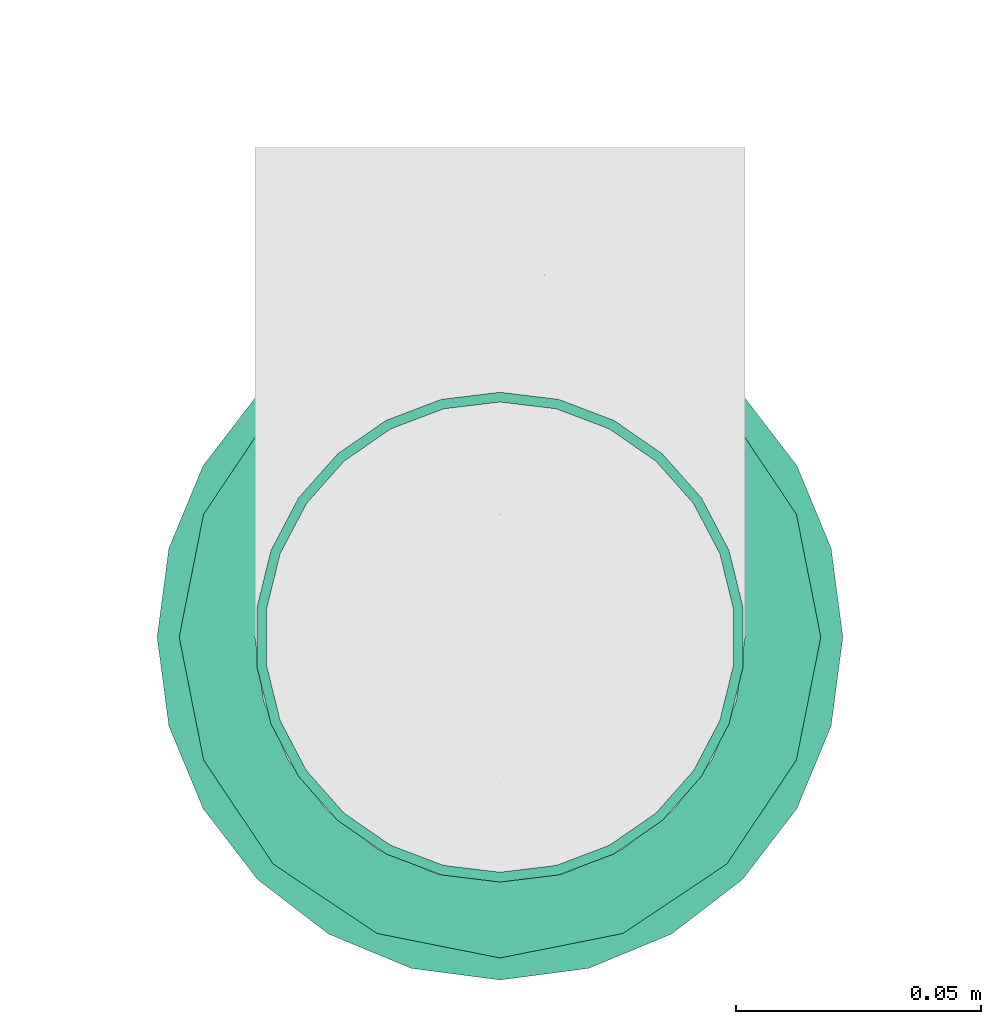
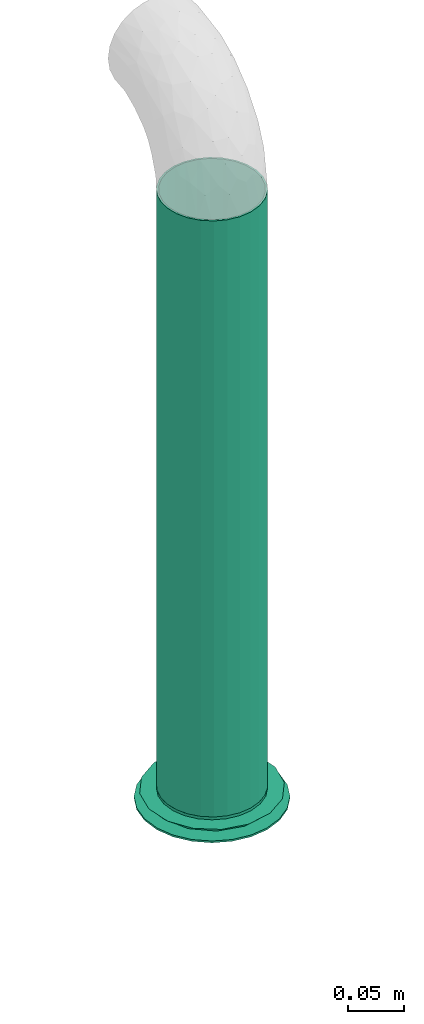
# One storey, part 55 of 103: 1 flow segment, 1 flow terminal.
"""IFC2X3 building model written with IfcOpenShell, lengths in millimetres."""

import ifcopenshell
import ifcopenshell.guid

model = None  # the IFC model being written
_history = None  # IfcOwnerHistory: only IFC2X3 demands one
_inside = {}  # id of a spatial element -> (the spatial element, [elements in it])
_under = {}  # id of a project, library or spatial element -> (it, [spatial elements below it])
_declared = {}  # id of a project -> (the project, [libraries it declares])
_typed = {}  # id of a type object -> (the type object, [elements of that type])
_made_of = {}  # id of a material, layer set ... -> (it, [elements and type objects made of it])


def new_model(schema):
    """Start an empty IFC model of exactly this schema.

    Asked for "IFC4X3", IfcOpenShell would pick the latest addendum, in which some entities
    have other attributes; the version numbers below select the first issue.
    IFC2X3 requires an IfcOwnerHistory on every rooted entity: one is made here for all.
    """
    global model, _history
    if schema == "IFC4X3":
        model = ifcopenshell.file(schema_version=(4, 3, 0, 0))
    else:
        model = ifcopenshell.file(schema=schema)
    _inside.clear()
    _under.clear()
    _declared.clear()
    _typed.clear()
    _made_of.clear()
    _history = None
    if model.schema == "IFC2X3":
        org = make("IfcOrganization", Name="unknown")
        user = make(
            "IfcPersonAndOrganization",
            ThePerson=make("IfcPerson", FamilyName="unknown"),
            TheOrganization=org,
        )
        app = make(
            "IfcApplication",
            ApplicationDeveloper=org,
            Version="unknown",
            ApplicationFullName="unknown",
            ApplicationIdentifier="unknown",
        )
        _history = make(
            "IfcOwnerHistory",
            OwningUser=user,
            OwningApplication=app,
            ChangeAction="ADDED",
            CreationDate=0,
        )
    return model


def make(cls, **values):
    """One entity of the class cls with the attributes given. An attribute that is None is left unset."""
    return model.create_entity(
        cls, **{name: value for name, value in values.items() if value is not None}
    )


def entity(cls, *values):
    """Any entity or typed value of the class cls, its attributes in the order of the schema. None: left unset."""
    e = model.create_entity(cls)
    for i, value in enumerate(values):
        if value is not None:
            e[i] = value
    return e


def rooted(cls, **values):
    """An entity with a GlobalId (a new one), such as an element, a storey or a relation."""
    return make(cls, GlobalId=ifcopenshell.guid.new(), OwnerHistory=_history, **values)


def si_unit(unit_type, name, prefix=None):
    """IfcSIUnit, for example si_unit("LENGTHUNIT", "METRE", prefix="MILLI")."""
    return make("IfcSIUnit", UnitType=unit_type, Prefix=prefix, Name=name)


def converted_unit(unit_type, name, factor, base, dimensions=None, offset=None):
    """IfcConversionBasedUnit, such as the inch: factor (a typed value) times the base unit."""
    return make(
        "IfcConversionBasedUnit"
        if offset is None
        else "IfcConversionBasedUnitWithOffset",
        ConversionOffset=offset,
        Dimensions=None
        if dimensions is None
        else entity("IfcDimensionalExponents", *dimensions),
        UnitType=unit_type,
        Name=name,
        ConversionFactor=make(
            "IfcMeasureWithUnit", ValueComponent=factor, UnitComponent=base
        ),
    )


def derived_unit(unit_type, elements):
    """IfcDerivedUnit: a product of units, each with its exponent."""
    return make(
        "IfcDerivedUnit",
        Elements=[
            make("IfcDerivedUnitElement", Unit=unit, Exponent=power)
            for unit, power in elements
        ],
        UnitType=unit_type,
    )


def assignment(units):
    """IfcUnitAssignment: the units of a project."""
    return None if units is None else make("IfcUnitAssignment", Units=units)


def point(xyz):
    """IfcCartesianPoint."""
    return None if xyz is None else make("IfcCartesianPoint", Coordinates=xyz)


def direction(xyz):
    """IfcDirection."""
    return None if xyz is None else make("IfcDirection", DirectionRatios=xyz)


def frame(location, z_axis=None, x_axis=None):
    """IfcAxis2Placement3D, a coordinate frame: its origin and axes. An axis left out is left unset."""
    return make(
        "IfcAxis2Placement3D",
        Location=point(location),
        Axis=direction(z_axis),
        RefDirection=direction(x_axis),
    )


def frame_2d(location, x_axis=None):
    """IfcAxis2Placement2D, a coordinate frame in the plane: its origin and x axis."""
    return make(
        "IfcAxis2Placement2D", Location=point(location), RefDirection=direction(x_axis)
    )


def origin_with_axes():
    """The frame at (0, 0, 0) with the z axis (0, 0, 1) and the x axis (1, 0, 0) written out."""
    return frame((0.0, 0.0, 0.0), z_axis=(0.0, 0.0, 1.0), x_axis=(1.0, 0.0, 0.0))


def origin_2d_with_axis():
    """The frame at (0, 0) in the plane with the x axis (1, 0) written out."""
    return frame_2d((0.0, 0.0), x_axis=(1.0, 0.0))


def place(relative_to, where):
    """IfcLocalPlacement: puts the frame where relative to a parent placement (None: the world)."""
    return make(
        "IfcLocalPlacement", PlacementRelTo=relative_to, RelativePlacement=where
    )


def context(
    kind, dimensions, precision=None, world=None, true_north=None, identifier=None
):
    """IfcGeometricRepresentationContext, for example the 3D "Model" context."""
    return make(
        "IfcGeometricRepresentationContext",
        ContextIdentifier=identifier,
        ContextType=kind,
        CoordinateSpaceDimension=dimensions,
        Precision=precision,
        WorldCoordinateSystem=world,
        TrueNorth=true_north,
    )


def subcontext(parent, identifier, kind, view, scale=None):
    """IfcGeometricRepresentationSubContext, for example "Body" below "Model"."""
    return make(
        "IfcGeometricRepresentationSubContext",
        ContextIdentifier=identifier,
        ContextType=kind,
        ParentContext=parent,
        TargetScale=scale,
        TargetView=view,
    )


def project(units=None, contexts=None):
    """IfcProject with its units and contexts."""
    return rooted(
        "IfcProject",
        Name="project",
        RepresentationContexts=contexts,
        UnitsInContext=assignment(units),
    )


def spatial(cls, under=None, at=None, **own):
    """A site, building, storey or space (cls), placed at a placement, below another one or the project."""
    s = rooted(cls, ObjectPlacement=at, **own)
    if under is not None:
        _under.setdefault(under.id(), (under, []))[1].append(s)
    return s


def profile(cls, at=None, kind="AREA", **sizes):
    """A parametric profile (cls). Its sizes go by their IFC names, for example OverallWidth=200.0."""
    return make(cls, ProfileType=kind, Position=at, **sizes)


def hollow_circle(**sizes):
    """IfcCircleHollowProfileDef."""
    return profile("IfcCircleHollowProfileDef", **sizes)


def extrude(swept, where, along, depth):
    """IfcExtrudedAreaSolid: the profile swept, set in the frame where, extruded along a direction by depth."""
    return make(
        "IfcExtrudedAreaSolid",
        SweptArea=swept,
        Position=where,
        ExtrudedDirection=direction(along),
        Depth=depth,
    )


def faces_of(points, faces, orient=None, outer=None):
    """IfcFace entities. A face is a list of loops; a loop is a list of indices into points, from 0.

    orient and outer hold one flag for each loop. By default every Orientation is true, the
    first loop of a face is its IfcFaceOuterBound and the others are IfcFaceBound.
    """
    made = []
    for i, loops in enumerate(faces):
        bounds = []
        for j, loop in enumerate(loops):
            is_outer = j == 0 if outer is None else outer[i][j]
            bounds.append(
                make(
                    "IfcFaceOuterBound" if is_outer else "IfcFaceBound",
                    Bound=make("IfcPolyLoop", Polygon=[points[k] for k in loop]),
                    Orientation=True if orient is None else orient[i][j],
                )
            )
        made.append(make("IfcFace", Bounds=bounds))
    return made


def open_shell(faces, orient=None, outer=None):
    """The faces of one IfcOpenShell. surface_model builds it on its shared points."""
    return ("IfcOpenShell", faces, orient, outer)


def surface_model(cls, points, shells):
    """IfcFaceBasedSurfaceModel or IfcShellBasedSurfaceModel (cls): surfaces that need not close."""
    shared = [point(p) for p in points]
    made = [make(c, CfsFaces=faces_of(shared, fs, o, b)) for c, fs, o, b in shells]
    if cls == "IfcFaceBasedSurfaceModel":
        return make(cls, FbsmFaces=made)
    return make(cls, SbsmBoundary=made)


def shape(context_of_items, identifier, shape_type, items):
    """IfcShapeRepresentation: the items that make up one representation, for example the "Body"."""
    return make(
        "IfcShapeRepresentation",
        ContextOfItems=context_of_items,
        RepresentationIdentifier=identifier,
        RepresentationType=shape_type,
        Items=items,
    )


def source(mapping_origin, context_of_items, identifier, shape_type, items):
    """IfcRepresentationMap: a shape defined once, which mapped items show again and again."""
    return make(
        "IfcRepresentationMap",
        MappingOrigin=mapping_origin,
        MappedRepresentation=shape(context_of_items, identifier, shape_type, items),
    )


def transform(
    local_origin,
    x_axis=None,
    y_axis=None,
    z_axis=None,
    scale=None,
    scale2=None,
    scale3=None,
    uniform=True,
):
    """IfcCartesianTransformationOperator3D, or its non-uniform kind. x_axis, y_axis, z_axis: its Axis1, 2, 3."""
    if uniform:
        return make(
            "IfcCartesianTransformationOperator3D",
            Axis1=direction(x_axis),
            Axis2=direction(y_axis),
            LocalOrigin=point(local_origin),
            Scale=scale,
            Axis3=direction(z_axis),
        )
    return make(
        "IfcCartesianTransformationOperator3DnonUniform",
        Axis1=direction(x_axis),
        Axis2=direction(y_axis),
        LocalOrigin=point(local_origin),
        Scale=scale,
        Axis3=direction(z_axis),
        Scale2=scale2,
        Scale3=scale3,
    )


def mapped(mapping_source, mapping_target):
    """IfcMappedItem: shows the shape of a source again, moved by a transform."""
    return make(
        "IfcMappedItem", MappingSource=mapping_source, MappingTarget=mapping_target
    )


def material(Name=None, Category=None):
    """IfcMaterial."""
    return make("IfcMaterial", Name=Name, Category=Category)


def layer(
    of_material, thickness, ventilated=None, Name=None, Category=None, Priority=None
):
    """IfcMaterialLayer: one layer of a wall or slab, of a material (None: an air gap)."""
    return make(
        "IfcMaterialLayer",
        Material=of_material,
        LayerThickness=thickness,
        IsVentilated=ventilated,
        Name=Name,
        Category=Category,
        Priority=Priority,
    )


def layer_set(layers, Name=None):
    """IfcMaterialLayerSet."""
    return make("IfcMaterialLayerSet", MaterialLayers=layers, LayerSetName=Name)


def layer_usage(for_layer_set, set_direction, sense, offset, extent=None):
    """IfcMaterialLayerSetUsage: how a layer set lies in its element."""
    return make(
        "IfcMaterialLayerSetUsage",
        ForLayerSet=for_layer_set,
        LayerSetDirection=set_direction,
        DirectionSense=sense,
        OffsetFromReferenceLine=offset,
        ReferenceExtent=extent,
    )


def made_of(thing, what):
    """Note that an element or type object is made of a material, layer set ...; save() writes the relation."""
    if what is not None:
        _made_of.setdefault(what.id(), (what, []))[1].append(thing)
    return thing


def type_object(cls, material=None, **own):
    """A type object (cls), such as IfcWallType, which elements share."""
    return made_of(rooted(cls, **own), material)


def element(
    cls,
    number,
    at=None,
    inside=None,
    cuts=None,
    type_object=None,
    material=None,
    context=None,
    identifier="Body",
    shape_type=None,
    held_by="IfcProductDefinitionShape",
    body=None,
    shapes=None,
    **own,
):
    """One element of the class cls, such as IfcWall. Its Tag is "e" and its number.

    at: its placement. inside: the storey or other place that contains it. cuts: it is an
    opening in that element (IfcRelVoidsElement). A single representation is given by context,
    identifier, shape_type and body (its items); several are given by shapes. held_by: the class
    of the entity that holds the representations. save() writes the other relations.
    """
    e = rooted(cls, Tag="e%d" % number, ObjectPlacement=at, **own)
    if body is not None:
        shapes = [shape(context, identifier, shape_type, body)]
    if shapes is not None:
        e.Representation = make(held_by, Representations=shapes)
    if inside is not None:
        _inside.setdefault(inside.id(), (inside, []))[1].append(e)
    if cuts is not None:
        rooted(
            "IfcRelVoidsElement", RelatingBuildingElement=cuts, RelatedOpeningElement=e
        )
    if type_object is not None:
        _typed.setdefault(type_object.id(), (type_object, []))[1].append(e)
    return made_of(e, material)


def aggregate(whole, parts):
    """IfcRelAggregates: a whole, such as a stair, and the parts it consists of."""
    return rooted("IfcRelAggregates", RelatingObject=whole, RelatedObjects=parts)


def save(model, path):
    """Write the relations noted so far, then the file.

    IfcRelAggregates (storeys below a building ...), IfcRelContainedInSpatialStructure (elements
    in a storey), IfcRelDefinesByType, IfcRelAssociatesMaterial and IfcRelDeclares: one each for
    every whole, place, type object, material and project.
    """
    for whole, parts in _under.values():
        aggregate(whole, parts)
    for where, things in _inside.values():
        rooted(
            "IfcRelContainedInSpatialStructure",
            RelatedElements=things,
            RelatingStructure=where,
        )
    for kind, things in _typed.values():
        rooted("IfcRelDefinesByType", RelatedObjects=things, RelatingType=kind)
    for what, things in _made_of.values():
        rooted("IfcRelAssociatesMaterial", RelatedObjects=things, RelatingMaterial=what)
    for by, libraries in _declared.values():
        rooted("IfcRelDeclares", RelatingContext=by, RelatedDefinitions=libraries)
    model.write(path)


model = new_model("IFC2X3")

# Units and contexts
model_context = context("Model", 3, precision=1e-05, world=origin_with_axes(), true_north=direction((0.0, 1.0)))
body_context = subcontext(model_context, "Body", "Model", "MODEL_VIEW")
ifc_project = project(units=[si_unit("AREAUNIT", "SQUARE_METRE"), si_unit("VOLUMEUNIT", "CUBIC_METRE", prefix="DECI"), si_unit("TIMEUNIT", "SECOND"), si_unit("THERMODYNAMICTEMPERATUREUNIT", "DEGREE_CELSIUS"), si_unit("PRESSUREUNIT", "PASCAL"), si_unit("MASSUNIT", "GRAM", prefix="KILO"), si_unit("LENGTHUNIT", "METRE", prefix="MILLI"), si_unit("POWERUNIT", "WATT"), si_unit("ELECTRICCURRENTUNIT", "AMPERE"), si_unit("ELECTRICVOLTAGEUNIT", "VOLT"), derived_unit("VOLUMETRICFLOWRATEUNIT", [(si_unit("VOLUMEUNIT", "CUBIC_METRE", prefix="DECI"), 1), (si_unit("TIMEUNIT", "SECOND"), -1)]), derived_unit("LINEARVELOCITYUNIT", [(si_unit("LENGTHUNIT", "METRE"), 1), (si_unit("TIMEUNIT", "SECOND"), -1)]), derived_unit("MASSDENSITYUNIT", [(si_unit("MASSUNIT", "GRAM", prefix="KILO"), 1), (si_unit("VOLUMEUNIT", "CUBIC_METRE"), -1)]), converted_unit("PLANEANGLEUNIT", "DEGREE", entity("IfcRatioMeasure", 0.01745), si_unit("PLANEANGLEUNIT", "RADIAN"), dimensions=[0, 0, 0, 0, 0, 0, 0])], contexts=[model_context])

# Site, building, storey
site_placement = place(None, origin_with_axes())
site = spatial("IfcSite", under=ifc_project, at=site_placement, CompositionType="ELEMENT")
building_placement = place(site_placement, origin_with_axes())
building = spatial("IfcBuilding", under=site, at=building_placement, Name="mc-building", CompositionType="ELEMENT")
storey_placement = place(building_placement, frame((0.0, 0.0, 5900.0), z_axis=(0.0, 0.0, 1.0), x_axis=(1.0, 0.0, 0.0)))
storey = spatial("IfcBuildingStorey", under=building, at=storey_placement, Name="3. Korrus", CompositionType="ELEMENT", Elevation=5900.0)

# Flow terminal
air_terminal_type = type_object("IfcAirTerminalType", Name="100", PredefinedType="NOTDEFINED")
shared_shape_1 = source(origin_with_axes(), body_context, "Body", "SurfaceModel", [
    surface_model("IfcShellBasedSurfaceModel", [(11.2, -70.0, 0.0), (11.2, -67.61481, -18.11733), (11.2, -67.61481, 18.11733), (6.2, -14.64625, -20.15883), (9.2, -22.36867, -22.36867), (6.2, -21.19625, -15.39997), (9.2, 16.375, -28.36233), (6.2, 8.09625, -24.91768), (6.2, 14.64625, -20.15883), (6.2, -8.09625, -24.91768), (9.2, -16.375, -28.36233), (6.2, 21.19625, -15.39997), (9.2, 22.36867, -22.36867), (9.2, -8.1875, -30.55617), (9.2, 8.1875, -30.55617), (9.2, 28.36233, -16.375), (9.2, -28.36233, -16.375), (6.2, 14.64625, 20.15883), (9.2, 22.36867, 22.36867), (6.2, 21.19625, 15.39997), (9.2, -16.375, 28.36233), (6.2, -8.09625, 24.91768), (6.2, -14.64625, 20.15883), (6.2, 8.09625, 24.91768), (9.2, 16.375, 28.36233), (6.2, -21.19625, 15.39997), (9.2, -22.36867, 22.36867), (9.2, 8.1875, 30.55617), (9.2, -8.1875, 30.55617), (9.2, -28.36233, 16.375), (9.2, 28.36233, 16.375), (6.2, -53.11211, -25.57744), (6.2, -36.75472, -46.08897), (6.2, -13.11761, -57.472), (6.2, 13.11761, -57.472), (6.2, 36.75472, -46.08897), (6.2, 53.11211, -25.57744), (0.0, -12.53288, -63.00706), (6.2, 0.0, -57.472), (0.0, -46.3155, -46.3155), (0.0, -35.69063, -53.4148), (0.0, 0.0, -65.5), (6.2, 44.93342, -35.83321), (0.0, 46.3155, -46.3155), (0.0, 35.69063, -53.4148), (6.2, -44.93342, -35.83321), (0.0, 12.53288, -63.00706), (0.0, 25.06576, -60.51411), (6.2, 56.03105, -12.78872), (0.0, 60.51411, -25.06576), (0.0, 63.00706, -12.53288), (0.0, 53.4148, -35.69063), (0.0, -25.06576, -60.51411), (0.0, -63.00706, -12.53288), (0.0, -60.51411, -25.06576), (6.2, -56.03105, -12.78872), (0.0, -53.4148, -35.69063), (6.2, 13.11761, 57.472), (0.0, 12.53288, 63.00706), (6.2, 0.0, 57.472), (6.2, 36.75472, 46.08897), (0.0, 46.3155, 46.3155), (0.0, 35.69063, 53.4148), (0.0, 0.0, 65.5), (6.2, -44.93342, 35.83321), (6.2, -36.75472, 46.08897), (0.0, -46.3155, 46.3155), (0.0, -35.69063, 53.4148), (6.2, 44.93342, 35.83321), (0.0, -12.53288, 63.00706), (0.0, -25.06576, 60.51411), (6.2, -13.11761, 57.472), (6.2, -56.03105, 12.78872), (0.0, -60.51411, 25.06576), (0.0, -63.00706, 12.53288), (0.0, -53.4148, 35.69063), (0.0, 25.06576, 60.51411), (0.0, 63.00706, 12.53288), (0.0, 60.51411, 25.06576), (6.2, 56.03105, 12.78872), (0.0, 53.4148, 35.69063), (-3.1, 43.30127, 25.0), (-3.1, -48.29629, -12.94095), (-3.1, -43.30127, 25.0), (-3.1, 25.0, -43.30127), (-3.1, 48.29629, -12.94095), (-3.1, 35.35534, -35.35534), (-3.1, -35.35534, -35.35534), (-3.1, -25.0, -43.30127), (-43.1, 43.46666, 11.64686), (-3.1, 38.97115, 22.5), (-3.1, 43.46666, 11.64686), (-3.1, 45.0, 0.0), (-43.1, 45.0, 0.0), (-3.1, 31.81981, 31.81981), (-43.1, 38.97115, 22.5), (-43.1, -38.97115, 22.5), (-3.1, -38.97115, 22.5), (-3.1, -31.81981, 31.81981), (-3.1, -43.46666, 11.64686), (-43.1, -43.46666, 11.64686), (-43.1, -45.0, 0.0), (-3.1, -45.0, 0.0), (-43.1, -43.46666, -11.64686), (-3.1, -38.97115, -22.5), (-3.1, -43.46666, -11.64686), (-3.1, -11.64686, -43.46666), (-3.1, -22.5, -38.97115), (-43.1, -22.5, -38.97115), (-3.1, -31.81981, -31.81981), (-43.1, -38.97115, -22.5), (-43.1, 22.5, -38.97115), (-3.1, 22.5, -38.97115), (-3.1, 11.64686, -43.46666), (-43.1, 38.97115, -22.5), (-3.1, 38.97115, -22.5), (-3.1, 31.81981, -31.81981), (-3.1, 43.46666, -11.64686), (-43.1, 43.46666, -11.64686), (11.2, -49.49747, -49.49747), (11.2, -35.0, -60.62178), (11.2, -18.11733, -67.61481), (11.2, 67.61481, 18.11733), (11.2, -60.62178, -35.0), (11.2, 18.11733, -67.61481), (11.2, 35.0, -60.62178), (11.2, 0.0, -70.0), (11.2, 60.62178, -35.0), (11.2, 67.61481, -18.11733), (11.2, 49.49747, -49.49747), (11.2, -49.49747, 49.49747), (11.2, -60.62178, 35.0), (11.2, -35.0, 60.62178), (11.2, -18.11733, 67.61481), (11.2, 0.0, 70.0), (11.2, 60.62178, 35.0), (11.2, 49.49747, 49.49747), (11.2, 70.0, 0.0), (11.2, 35.0, 60.62178), (11.2, 18.11733, 67.61481), (9.2, -49.49747, 49.49747), (9.2, -35.0, 60.62178), (9.2, -18.11733, 67.61481), (9.2, -67.61481, 18.11733), (9.2, -70.0, 0.0), (9.2, -60.62178, 35.0), (9.2, 67.61481, 18.11733), (9.2, 35.0, 60.62178), (9.2, 18.11733, 67.61481), (9.2, 0.0, 70.0), (9.2, 60.62178, 35.0), (9.2, 49.49747, 49.49747), (9.2, -67.61481, -18.11733), (9.2, -49.49747, -49.49747), (9.2, -60.62178, -35.0), (9.2, -18.11733, -67.61481), (9.2, 70.0, 0.0), (9.2, -35.0, -60.62178), (9.2, 0.0, -70.0), (9.2, 60.62178, -35.0), (9.2, 49.49747, -49.49747), (9.2, 67.61481, -18.11733), (9.2, 35.0, -60.62178), (9.2, 18.11733, -67.61481), (9.2, -32.75, 0.0), (9.2, 0.0, 32.75), (9.2, 32.75, 0.0), (9.2, 0.0, -32.75), (6.2, 26.2, 0.0), (6.2, -26.2, 0.0), (9.2, -31.06579, -6.28555), (6.2, -23.69812, -7.69999), (6.2, 23.69812, -7.69999), (9.2, 31.06579, -6.28555), (6.2, 0.0, -24.91768), (9.2, 31.06579, 6.28555), (6.2, 23.69812, 7.69999), (6.2, -23.69812, 7.69999), (9.2, -31.06579, 6.28555), (6.2, 0.0, 24.91768), (6.2, 53.11211, 25.57744), (6.2, 58.95, 0.0), (6.2, -53.11211, 25.57744), (6.2, -58.95, 0.0), (0.0, 65.5, 0.0), (0.0, -65.5, 0.0), (6.2, -24.93616, -51.78048), (6.2, 24.93616, -51.78048), (6.2, 24.93616, 51.78048), (6.2, -24.93616, 51.78048), (-3.1, 0.0, 50.0), (-3.1, 35.35534, 35.35534), (-3.1, -12.94095, 48.29629), (-3.1, -25.0, 43.30127), (-3.1, -35.35534, 35.35534), (-3.1, 25.0, 43.30127), (-3.1, 12.94095, 48.29629), (-3.1, 48.29629, 12.94095), (-3.1, 50.0, 0.0), (-3.1, -50.0, 0.0), (-3.1, -48.29629, 12.94095), (-3.1, -43.30127, -25.0), (-3.1, -12.94095, -48.29629), (-3.1, 0.0, -50.0), (-3.1, 43.30127, -25.0), (-3.1, 12.94095, -48.29629), (0.0, -12.94095, -48.29629), (0.0, 0.0, -50.0), (0.0, -25.0, -43.30127), (0.0, -35.35534, -35.35534), (0.0, -48.29629, -12.94095), (0.0, 25.0, -43.30127), (0.0, -43.30127, -25.0), (0.0, 43.30127, 25.0), (0.0, 12.94095, -48.29629), (0.0, 43.30127, -25.0), (0.0, 48.29629, -12.94095), (0.0, 35.35534, -35.35534), (0.0, 50.0, 0.0), (0.0, -50.0, 0.0), (0.0, -48.29629, 12.94095), (0.0, -43.30127, 25.0), (0.0, -35.35534, 35.35534), (0.0, -12.94095, 48.29629), (0.0, -25.0, 43.30127), (0.0, 35.35534, 35.35534), (0.0, 0.0, 50.0), (0.0, 48.29629, 12.94095), (0.0, 25.0, 43.30127), (0.0, 12.94095, 48.29629), (-43.1, -22.5, 38.97115), (-43.1, -11.64686, 43.46666), (-43.1, 0.0, 45.0), (-43.1, 11.64686, 43.46666), (-43.1, -31.81981, 31.81981), (-43.1, 31.81981, 31.81981), (-43.1, 22.5, 38.97115), (-43.1, -31.81981, -31.81981), (-43.1, 31.81981, -31.81981), (-43.1, -11.64686, -43.46666), (-43.1, 11.64686, -43.46666), (-43.1, 0.0, -45.0), (-3.1, 0.0, -45.0), (-3.1, 0.0, 45.0), (-3.1, -22.5, 38.97115), (-3.1, -11.64686, 43.46666), (-3.1, 11.64686, 43.46666), (-3.1, 22.5, 38.97115)], [open_shell([[[0, 1, 2]], [[3, 4, 5]], [[6, 7, 8]], [[3, 9, 10]], [[4, 3, 10]], [[11, 12, 8]], [[13, 10, 9]], [[7, 6, 14]], [[6, 8, 12]], [[12, 11, 15]], [[16, 5, 4]], [[17, 18, 19]], [[20, 21, 22]], [[17, 23, 24]], [[18, 17, 24]], [[25, 26, 22]], [[27, 24, 23]], [[21, 20, 28]], [[20, 22, 26]], [[26, 25, 29]], [[30, 19, 18]], [[31, 32, 33]], [[34, 35, 36]], [[33, 37, 38]], [[32, 39, 40]], [[41, 38, 37]], [[42, 35, 43]], [[44, 43, 35]], [[39, 32, 45]], [[46, 47, 34]], [[48, 49, 50]], [[38, 46, 34]], [[42, 43, 51]], [[33, 52, 37]], [[53, 54, 55]], [[46, 38, 41]], [[56, 39, 45]], [[57, 58, 59]], [[60, 61, 62]], [[63, 59, 58]], [[64, 65, 66]], [[67, 66, 65]], [[61, 60, 68]], [[69, 70, 71]], [[72, 73, 74]], [[59, 69, 71]], [[64, 66, 75]], [[57, 76, 58]], [[77, 78, 79]], [[69, 59, 63]], [[80, 61, 68]], [[81, 82, 83]], [[84, 85, 86]], [[87, 82, 88]], [[89, 90, 91]], [[91, 92, 93]], [[94, 90, 95]], [[96, 97, 98]], [[99, 97, 100]], [[101, 102, 99]], [[103, 104, 105]], [[105, 102, 101]], [[106, 107, 108]], [[109, 104, 110]], [[111, 112, 113]], [[114, 115, 116]], [[117, 115, 118]], [[93, 92, 117]], [[119, 120, 121]], [[1, 119, 121]], [[122, 1, 121]], [[123, 119, 1]], [[124, 122, 121]], [[125, 122, 124]], [[121, 126, 124]], [[127, 128, 129]], [[129, 128, 122]], [[129, 122, 125]], [[130, 131, 2]], [[132, 130, 2]], [[122, 133, 2]], [[132, 2, 133]], [[134, 133, 122]], [[135, 136, 122]], [[122, 128, 137]], [[136, 138, 122]], [[139, 122, 138]], [[122, 139, 134]], [[2, 1, 122]], [[140, 141, 142]], [[143, 140, 142]], [[142, 144, 143]], [[145, 140, 143]], [[146, 144, 142]], [[147, 146, 148]], [[149, 148, 146]], [[150, 146, 151]], [[147, 151, 146]], [[146, 142, 149]], [[146, 152, 144]], [[153, 154, 152]], [[155, 153, 152]], [[146, 156, 155]], [[157, 153, 155]], [[158, 155, 156]], [[159, 160, 161]], [[156, 161, 160]], [[160, 162, 156]], [[163, 156, 162]], [[163, 158, 156]], [[152, 146, 155]], [[156, 128, 161]], [[161, 127, 159]], [[162, 160, 125]], [[129, 160, 159]], [[163, 162, 124]], [[128, 127, 161]], [[156, 137, 128]], [[162, 125, 124]], [[125, 160, 129]], [[159, 127, 129]], [[163, 124, 126]], [[126, 158, 163]], [[158, 121, 155]], [[155, 120, 157]], [[154, 153, 123]], [[119, 153, 157]], [[152, 154, 1]], [[120, 119, 157]], [[155, 121, 120]], [[152, 1, 0]], [[1, 154, 123]], [[153, 119, 123]], [[152, 0, 144]], [[126, 121, 158]], [[144, 2, 143]], [[143, 131, 145]], [[141, 140, 132]], [[130, 140, 145]], [[142, 141, 133]], [[2, 131, 143]], [[144, 0, 2]], [[141, 132, 133]], [[132, 140, 130]], [[145, 131, 130]], [[142, 133, 134]], [[134, 149, 142]], [[149, 139, 148]], [[148, 138, 147]], [[150, 151, 135]], [[136, 151, 147]], [[146, 150, 122]], [[138, 136, 147]], [[148, 139, 138]], [[146, 122, 137]], [[122, 150, 135]], [[151, 136, 135]], [[146, 137, 156]], [[134, 139, 149]], [[30, 24, 164]], [[24, 20, 164]], [[165, 20, 24]], [[164, 20, 29]], [[166, 30, 16]], [[16, 6, 166]], [[167, 6, 10]], [[30, 164, 16]], [[10, 6, 16]], [[6, 15, 166]], [[21, 19, 11]], [[23, 19, 21]], [[11, 19, 168]], [[7, 25, 21]], [[7, 5, 169]], [[21, 11, 7]], [[9, 5, 7]], [[169, 25, 7]], [[170, 164, 169]], [[170, 171, 16]], [[11, 172, 15]], [[172, 168, 173]], [[174, 13, 9]], [[166, 173, 168]], [[172, 173, 15]], [[169, 171, 170]], [[5, 16, 171]], [[167, 174, 14]], [[174, 167, 13]], [[14, 174, 7]], [[175, 166, 168]], [[175, 176, 30]], [[25, 177, 29]], [[177, 169, 178]], [[179, 27, 23]], [[164, 178, 169]], [[177, 178, 29]], [[168, 176, 175]], [[19, 30, 176]], [[165, 179, 28]], [[179, 165, 27]], [[28, 179, 21]], [[180, 60, 57]], [[181, 180, 65]], [[65, 57, 71]], [[180, 57, 65]], [[65, 182, 181]], [[182, 36, 181]], [[183, 34, 36]], [[31, 34, 183]], [[31, 33, 34]], [[182, 183, 36]], [[70, 63, 49]], [[70, 73, 66]], [[49, 63, 184]], [[78, 76, 61]], [[76, 78, 184]], [[184, 63, 76]], [[73, 70, 49]], [[39, 54, 185]], [[41, 39, 185]], [[52, 39, 41]], [[43, 185, 49]], [[185, 43, 47]], [[185, 47, 41]], [[73, 49, 185]], [[55, 54, 31]], [[31, 54, 56]], [[52, 186, 40]], [[53, 55, 183]], [[56, 45, 31]], [[185, 53, 183]], [[32, 40, 186]], [[33, 186, 52]], [[44, 35, 187]], [[49, 36, 51]], [[34, 47, 187]], [[42, 51, 36]], [[187, 47, 44]], [[49, 48, 36]], [[48, 50, 181]], [[184, 181, 50]], [[79, 78, 180]], [[180, 78, 80]], [[76, 188, 62]], [[77, 79, 181]], [[80, 68, 180]], [[184, 77, 181]], [[60, 62, 188]], [[57, 188, 76]], [[67, 65, 189]], [[73, 182, 75]], [[71, 70, 189]], [[64, 75, 182]], [[189, 70, 67]], [[73, 72, 182]], [[72, 74, 183]], [[185, 183, 74]], [[190, 191, 192]], [[193, 192, 194]], [[83, 192, 81]], [[194, 192, 83]], [[195, 191, 196]], [[191, 190, 196]], [[197, 198, 81]], [[81, 192, 191]], [[198, 84, 81]], [[199, 200, 83]], [[81, 88, 82]], [[201, 82, 87]], [[88, 81, 202]], [[81, 203, 202]], [[204, 86, 85]], [[205, 203, 84]], [[84, 198, 85]], [[81, 84, 203]], [[199, 83, 82]], [[206, 207, 208]], [[209, 208, 210]], [[210, 208, 211]], [[212, 209, 210]], [[210, 211, 213]], [[214, 211, 207]], [[211, 208, 207]], [[215, 216, 217]], [[211, 217, 216]], [[216, 218, 211]], [[219, 210, 220]], [[221, 210, 213]], [[222, 221, 223]], [[213, 223, 221]], [[224, 222, 223]], [[223, 225, 226]], [[227, 213, 218]], [[218, 213, 211]], [[228, 229, 225]], [[223, 213, 225]], [[226, 225, 229]], [[221, 220, 210]], [[199, 220, 200]], [[200, 221, 83]], [[193, 194, 224]], [[222, 194, 83]], [[192, 193, 223]], [[220, 221, 200]], [[199, 219, 220]], [[193, 224, 223]], [[224, 194, 222]], [[83, 221, 222]], [[192, 223, 226]], [[226, 190, 192]], [[190, 229, 196]], [[196, 228, 195]], [[81, 191, 213]], [[225, 191, 195]], [[197, 81, 227]], [[228, 225, 195]], [[196, 229, 228]], [[197, 227, 218]], [[227, 81, 213]], [[191, 225, 213]], [[197, 218, 198]], [[226, 229, 190]], [[198, 216, 85]], [[85, 215, 204]], [[84, 86, 211]], [[217, 86, 204]], [[205, 84, 214]], [[216, 215, 85]], [[198, 218, 216]], [[84, 211, 214]], [[211, 86, 217]], [[204, 215, 217]], [[205, 214, 207]], [[207, 203, 205]], [[203, 206, 202]], [[202, 208, 88]], [[201, 87, 212]], [[209, 87, 88]], [[82, 201, 210]], [[208, 209, 88]], [[202, 206, 208]], [[82, 210, 219]], [[210, 201, 212]], [[87, 209, 212]], [[82, 219, 199]], [[207, 206, 203]], [[230, 231, 232]], [[230, 232, 233]], [[230, 100, 96]], [[234, 230, 96]], [[100, 230, 233]], [[235, 89, 236]], [[100, 233, 236]], [[95, 89, 235]], [[118, 89, 93]], [[118, 236, 89]], [[118, 100, 236]], [[110, 103, 101]], [[237, 110, 101]], [[238, 108, 101]], [[237, 101, 108]], [[239, 108, 238]], [[114, 238, 118]], [[238, 101, 118]], [[240, 241, 111]], [[238, 111, 241]], [[238, 241, 239]], [[100, 118, 101]], [[106, 242, 107]], [[107, 112, 109]], [[102, 105, 104]], [[112, 104, 109]], [[92, 104, 117]], [[113, 112, 242]], [[112, 107, 242]], [[115, 117, 116]], [[112, 116, 117]], [[112, 117, 104]], [[92, 102, 104]], [[97, 99, 243]], [[98, 97, 244]], [[243, 245, 244]], [[97, 243, 244]], [[246, 243, 99]], [[90, 94, 91]], [[92, 91, 247]], [[94, 247, 91]], [[247, 99, 92]], [[247, 246, 99]], [[102, 92, 99]], [[101, 99, 100]], [[100, 97, 96]], [[230, 234, 244]], [[98, 234, 96]], [[231, 230, 245]], [[245, 230, 244]], [[244, 234, 98]], [[245, 243, 231]], [[243, 232, 231]], [[236, 233, 246]], [[236, 247, 235]], [[89, 95, 90]], [[94, 95, 235]], [[93, 89, 91]], [[232, 246, 233]], [[246, 247, 236]], [[243, 246, 232]], [[247, 94, 235]], [[93, 117, 118]], [[118, 115, 114]], [[111, 238, 112]], [[116, 238, 114]], [[240, 111, 113]], [[112, 238, 116]], [[240, 113, 242]], [[242, 241, 240]], [[108, 239, 106]], [[108, 107, 237]], [[103, 110, 104]], [[109, 110, 237]], [[101, 103, 105]], [[241, 106, 239]], [[242, 106, 241]], [[107, 109, 237]]])]),
])
flow_terminal_placement = place(storey_placement, frame((25689.63788, 573.88887, 2458.87044), z_axis=(1.0, 0.0, 0.0), x_axis=(0.0, 0.0, -1.0)))
element("IfcFlowTerminal", 1, at=flow_terminal_placement, inside=storey, type_object=air_terminal_type, Name="100", context=body_context, shape_type="MappedRepresentation", body=[
    mapped(shared_shape_1, transform((0.0, 0.0, 0.0), scale=1.0)),
])

# Flow segment
ifc_material = material(Name="FZ1")
ifc_layer = layer(ifc_material, 0.0)
ifc_layer_set = layer_set([ifc_layer], Name="FZ1")
ifc_layer_usage = layer_usage(ifc_layer_set, "AXIS1", "POSITIVE", 0.0)
duct_segment_type = type_object("IfcDuctSegmentType", Name="Safe", PredefinedType="RIGIDSEGMENT")
shared_shape_2 = source(origin_with_axes(), body_context, "Body", "SweptSolid", [
    extrude(hollow_circle(Radius=50.0, WallThickness=2.0, at=origin_2d_with_axis()), frame((0.0, 0.0, 0.0), z_axis=(1.0, 0.0, 0.0), x_axis=(0.0, 1.0, 0.0)), (0.0, 0.0, 1.0), 653.0),
])
flow_segment_placement = place(storey_placement, frame((25689.63788, 573.88887, 2461.97044), z_axis=(1.0, 0.0, 0.0), x_axis=(0.0, 0.0, 1.0)))
element("IfcFlowSegment", 2, at=flow_segment_placement, inside=storey, type_object=duct_segment_type, material=ifc_layer_usage, Name="Safe", context=body_context, shape_type="MappedRepresentation", body=[
    mapped(shared_shape_2, transform((0.0, 0.0, 0.0), scale=1.0)),
])

save(model, "model.ifc")
